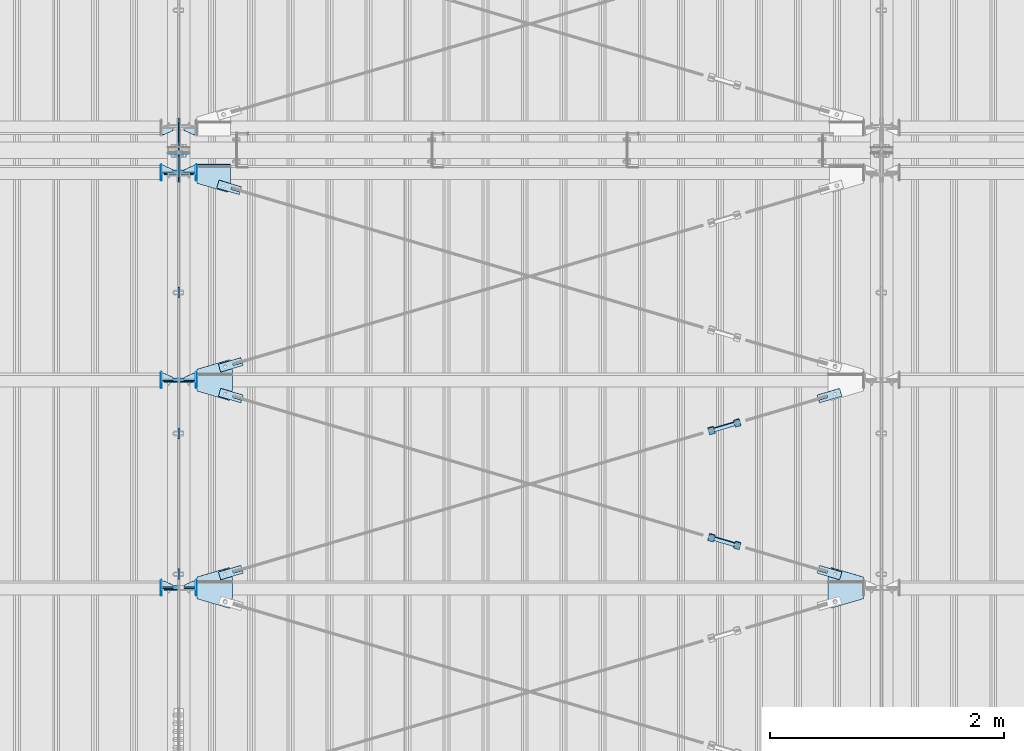
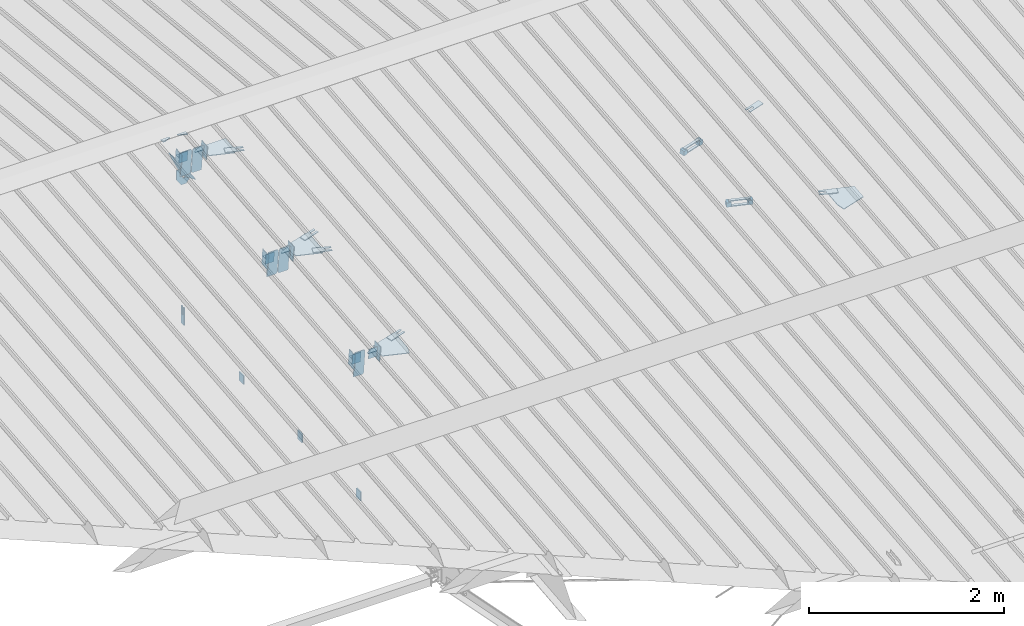
# One storey, part 151 of 709: 50 plates, 6 openings, 22 elements without a shape of their own.
"""IFC4 building model written with IfcOpenShell, lengths in millimetres."""

from ifc_helpers import new_model, si_unit, direction, frame, origin_with_axes, place, context, subcontext, project, spatial, line, indexed_curve, outline, extrude, material, element, aggregate, save


model = new_model("IFC4")

# Units and contexts
model_context = context("Model", 3, precision=0.2, world=origin_with_axes(), true_north=direction((0.0, 1.0)))
body_context = subcontext(model_context, "Body", "Model", "MODEL_VIEW")
ifc_project = project(units=[si_unit("LENGTHUNIT", "METRE", prefix="MILLI"), si_unit("AREAUNIT", "SQUARE_METRE"), si_unit("VOLUMEUNIT", "CUBIC_METRE"), si_unit("MASSUNIT", "GRAM", prefix="KILO"), si_unit("TIMEUNIT", "SECOND"), si_unit("PLANEANGLEUNIT", "RADIAN"), si_unit("SOLIDANGLEUNIT", "STERADIAN"), si_unit("THERMODYNAMICTEMPERATUREUNIT", "DEGREE_CELSIUS"), si_unit("LUMINOUSINTENSITYUNIT", "LUMEN")], contexts=[model_context])

# Site, building, storey
site_placement = place(None, origin_with_axes())
site = spatial("IfcSite", under=ifc_project, at=site_placement, CompositionType="ELEMENT")
building_placement = place(site_placement, origin_with_axes())
building = spatial("IfcBuilding", under=site, at=building_placement, Name="Undefined", CompositionType="ELEMENT")
storey_placement = place(building_placement, origin_with_axes())
storey = spatial("IfcBuildingStorey", under=building, at=storey_placement, Name="Undefined", CompositionType="ELEMENT", Elevation=0.0)

# Assembly, plates
assembly_1_placement = place(storey_placement, frame((40000.0, 346.0, 7089.70002), z_axis=(1.0, 0.0, 0.0), x_axis=(0.0, 0.9950371902, 0.099503719)))
assembly_1 = element("IfcElementAssembly", 1, at=assembly_1_placement, inside=storey)
ifc_material_1 = material(Name="C355-6", Category="STEEL")
plate_1_placement = place(assembly_1_placement, frame((10515.43997, 163.0, 127.0), z_axis=(-1.0, 0.0, 0.0), x_axis=(0.0, 0.0, -1.0)))
plate_1 = element("IfcPlate", 2, at=plate_1_placement, material=ifc_material_1, ObjectType="589", context=body_context, shape_type="SolidModel", body=[
    extrude(outline(indexed_curve([(0.0, 0.0), (108.0, 0.0), (123.0, 15.0), (123.0, 311.0), (108.0, 326.0), (0.0, 326.0)], segments=[line(1, 2, 3, 4, 5, 6, 1)])), frame((0.0, 0.0, 4.0), z_axis=(0.0, 0.0, 1.0), x_axis=(1.0, 0.0, 0.0)), (0.0, 0.0, -1.0), 8.0),
])
plate_2_placement = place(assembly_1_placement, frame((8733.29528, 163.0, 127.0), z_axis=(-1.0, 0.0, 0.0), x_axis=(0.0, 0.0, -1.0)))
plate_2 = element("IfcPlate", 3, at=plate_2_placement, material=ifc_material_1, ObjectType="585", context=body_context, shape_type="SolidModel", body=[
    extrude(outline(indexed_curve([(0.0, 0.0), (108.0, 0.0), (123.0, 15.0), (123.0, 311.0), (108.0, 326.0), (0.0, 326.0)], segments=[line(1, 2, 3, 4, 5, 6, 1)])), frame((0.0, 0.0, 4.0), z_axis=(0.0, 0.0, 1.0), x_axis=(1.0, 0.0, 0.0)), (0.0, 0.0, -1.0), 8.0),
])
plate_3_placement = place(assembly_1_placement, frame((8733.29528, 163.0, -127.0), z_axis=(1.0, 0.0, 0.0), x_axis=(0.0, 0.0, 1.0)))
plate_3 = element("IfcPlate", 4, at=plate_3_placement, material=ifc_material_1, ObjectType="585", context=body_context, shape_type="SolidModel", body=[
    extrude(outline(indexed_curve([(0.0, 0.0), (108.0, 0.0), (123.0, 15.0), (123.0, 311.0), (108.0, 326.0), (0.0, 326.0)], segments=[line(1, 2, 3, 4, 5, 6, 1)])), frame((0.0, 0.0, 4.0), z_axis=(0.0, 0.0, 1.0), x_axis=(1.0, 0.0, 0.0)), (0.0, 0.0, -1.0), 8.0),
])
plate_4_placement = place(assembly_1_placement, frame((6951.15059, 163.0, -127.0), z_axis=(1.0, 0.0, 0.0), x_axis=(0.0, 0.0, 1.0)))
plate_4 = element("IfcPlate", 5, at=plate_4_placement, material=ifc_material_1, ObjectType="585", context=body_context, shape_type="SolidModel", body=[
    extrude(outline(indexed_curve([(0.0, 0.0), (108.0, 0.0), (123.0, 15.0), (123.0, 311.0), (108.0, 326.0), (0.0, 326.0)], segments=[line(1, 2, 3, 4, 5, 6, 1)])), frame((0.0, 0.0, 4.0), z_axis=(0.0, 0.0, 1.0), x_axis=(1.0, 0.0, 0.0)), (0.0, 0.0, -1.0), 8.0),
])
plate_5_placement = place(assembly_1_placement, frame((10515.43997, 163.0, -127.0), z_axis=(1.0, 0.0, 0.0), x_axis=(0.0, 0.0, 1.0)))
plate_5 = element("IfcPlate", 6, at=plate_5_placement, material=ifc_material_1, ObjectType="589", context=body_context, shape_type="SolidModel", body=[
    extrude(outline(indexed_curve([(0.0, 0.0), (108.0, 0.0), (123.0, 15.0), (123.0, 311.0), (108.0, 326.0), (0.0, 326.0)], segments=[line(1, 2, 3, 4, 5, 6, 1)])), frame((0.0, 0.0, 4.0), z_axis=(0.0, 0.0, 1.0), x_axis=(1.0, 0.0, 0.0)), (0.0, 0.0, -1.0), 8.0),
])
plate_6_placement = place(assembly_1_placement, frame((10651.77731, -302.35483, 0.0), z_axis=(0.0, 0.0, 1.0), x_axis=(0.099503719, 0.9950371902, 0.0)))
plate_6 = element("IfcPlate", 7, at=plate_6_placement, material=ifc_material_1, ObjectType="439", context=body_context, shape_type="SolidModel", body=[
    extrude(outline(indexed_curve([(0.0, 0.0), (130.0, 0.0), (105.12407, 248.7593)], segments=[line(1, 2, 3, 1)])), frame((0.0, 0.0, 6.0), z_axis=(0.0, 0.0, 1.0), x_axis=(1.0, 0.0, 0.0)), (0.0, 0.0, -1.0), 12.0),
])
aggregate(assembly_1, [plate_1, plate_2, plate_3, plate_4, plate_5, plate_6])

# Assembly, plate
assembly_2_placement = place(storey_placement, frame((40000.0, 21654.0, 7089.70002), z_axis=(-1.0, 0.0, 0.0), x_axis=(0.0, -0.9950371902, 0.099503719)))
assembly_2 = element("IfcElementAssembly", 8, at=assembly_2_placement, inside=storey)
plate_7_placement = place(assembly_2_placement, frame((10651.77731, -302.35483, 0.0), z_axis=(0.0, 0.0, 1.0), x_axis=(0.099503719, 0.9950371902, 0.0)))
plate_7 = element("IfcPlate", 9, at=plate_7_placement, material=ifc_material_1, ObjectType="439", context=body_context, shape_type="SolidModel", body=[
    extrude(outline(indexed_curve([(0.0, 0.0), (130.0, 0.0), (105.12407, 248.7593)], segments=[line(1, 2, 3, 1)])), frame((0.0, 0.0, 6.0), z_axis=(0.0, 0.0, 1.0), x_axis=(1.0, 0.0, 0.0)), (0.0, 0.0, -1.0), 12.0),
])
aggregate(assembly_2, [plate_7])

# Assembly, plates
assembly_3_placement = place(storey_placement, frame((40000.0, 10985.0, 8155.10002), z_axis=(0.0, -1.0, 0.0), x_axis=(0.0, 0.0, -1.0)))
assembly_3 = element("IfcElementAssembly", 10, at=assembly_3_placement, inside=storey)
plate_8_placement = place(assembly_3_placement, frame((2165.1, 0.0, 30.0), z_axis=(0.0, 1.0, 0.0), x_axis=(0.0, 0.0, -1.0)))
plate_8 = element("IfcPlate", 11, at=plate_8_placement, material=ifc_material_1, ObjectType="441", context=body_context, shape_type="SolidModel", body=[
    extrude(outline(indexed_curve([(0.0, 0.0), (60.0, 0.0), (60.0, 220.0), (41.0, 220.0), (41.0, 120.0), (19.0, 120.0), (19.0, 220.0), (0.0, 220.0)], segments=[line(1, 2, 3, 4, 5, 6, 7, 8, 1)])), frame((0.0, 0.0, 6.0), z_axis=(0.0, 0.0, 1.0), x_axis=(1.0, 0.0, 0.0)), (0.0, 0.0, -1.0), 12.0),
])
plate_9_placement = place(assembly_3_placement, frame((206.36285, -87.0, 14.0), z_axis=(0.0, 0.0, -1.0), x_axis=(0.0, 1.0, 0.0)))
plate_9 = element("IfcPlate", 12, at=plate_9_placement, material=ifc_material_1, ObjectType="440", context=body_context, shape_type="SolidModel", body=[
    extrude(outline(indexed_curve([(0.0, 0.0), (71.0, 0.0), (71.0, 120.0), (103.0, 120.0), (103.0, 0.0), (174.0, 0.0), (174.0, 120.0), (117.0, 200.0), (57.0, 200.0), (0.0, 120.0)], segments=[line(1, 2, 3, 4, 5, 6, 7, 8, 9, 10, 1)])), frame((0.0, 0.0, 4.0), z_axis=(0.0, 0.0, 1.0), x_axis=(1.0, 0.0, 0.0)), (0.0, 0.0, -1.0), 8.0),
])
aggregate(assembly_3, [plate_8, plate_9])

# Assembly, plate
assembly_4_placement = place(storey_placement, frame((40000.0, 7334.75, 6100.00002), z_axis=(-1.0, 0.0, 0.0), x_axis=(0.0, 1.0, 0.0)))
assembly_4 = element("IfcElementAssembly", 13, at=assembly_4_placement, inside=storey)
plate_10_placement = place(assembly_4_placement, origin_with_axes())
plate_10 = element("IfcPlate", 14, at=plate_10_placement, material=ifc_material_1, ObjectType="491", context=body_context, shape_type="SolidModel", body=[
    extrude(outline(indexed_curve([(0.0, 0.0), (90.0, 0.0), (90.0, 110.0), (0.0, 110.0)], segments=[line(1, 2, 3, 4, 1)])), frame((0.0, 0.0, 6.0), z_axis=(0.0, 0.0, 1.0), x_axis=(1.0, 0.0, 0.0)), (0.0, 0.0, -1.0), 12.0),
])
aggregate(assembly_4, [plate_10])

assembly_5_placement = place(storey_placement, frame((40000.0, 8536.5, 6100.00002), z_axis=(-1.0, 0.0, 0.0), x_axis=(0.0, 1.0, 0.0)))
assembly_5 = element("IfcElementAssembly", 15, at=assembly_5_placement, inside=storey)
plate_11_placement = place(assembly_5_placement, origin_with_axes())
plate_11 = element("IfcPlate", 16, at=plate_11_placement, material=ifc_material_1, ObjectType="491", context=body_context, shape_type="SolidModel", body=[
    extrude(outline(indexed_curve([(0.0, 0.0), (90.0, 0.0), (90.0, 110.0), (0.0, 110.0)], segments=[line(1, 2, 3, 4, 1)])), frame((0.0, 0.0, 6.0), z_axis=(0.0, 0.0, 1.0), x_axis=(1.0, 0.0, 0.0)), (0.0, 0.0, -1.0), 12.0),
])
aggregate(assembly_5, [plate_11])

assembly_6_placement = place(storey_placement, frame((40000.0, 9738.25, 6100.00002), z_axis=(-1.0, 0.0, 0.0), x_axis=(0.0, 1.0, 0.0)))
assembly_6 = element("IfcElementAssembly", 17, at=assembly_6_placement, inside=storey)
plate_12_placement = place(assembly_6_placement, origin_with_axes())
plate_12 = element("IfcPlate", 18, at=plate_12_placement, material=ifc_material_1, ObjectType="491", context=body_context, shape_type="SolidModel", body=[
    extrude(outline(indexed_curve([(0.0, 0.0), (90.0, 0.0), (90.0, 110.0), (0.0, 110.0)], segments=[line(1, 2, 3, 4, 1)])), frame((0.0, 0.0, 6.0), z_axis=(0.0, 0.0, 1.0), x_axis=(1.0, 0.0, 0.0)), (0.0, 0.0, -1.0), 12.0),
])
aggregate(assembly_6, [plate_12])

# Assembly, plate, voiding feature
assembly_7_placement = place(storey_placement, frame((40000.0, 7262.55385, 7862.7594), z_axis=(0.2847296511, -0.9538504697, -0.095385047), x_axis=(0.9586078582, 0.2833165921, 0.028331659)))
assembly_7 = element("IfcElementAssembly", 19, at=assembly_7_placement, inside=storey)
plate_13_placement = place(assembly_7_placement, frame((363.68279, 0.0, -35.0), z_axis=(0.0, 1.0, 0.0), x_axis=(0.0, 0.0, 1.0)))
plate_13 = element("IfcPlate", 20, at=plate_13_placement, material=ifc_material_1, ObjectType="574", context=body_context, shape_type="SolidModel", body=[
    extrude(outline(indexed_curve([(0.0, 0.0), (70.0, 0.0), (70.0, 200.0), (0.0, 200.0)], segments=[line(1, 2, 3, 4, 1)])), frame((0.0, 0.0, 4.0), z_axis=(0.0, 0.0, 1.0), x_axis=(1.0, 0.0, 0.0)), (0.0, 0.0, -1.0), 8.0),
])
voiding_feature_1_placement = place(plate_13_placement, frame((24.0, 120.0, 0.0), z_axis=(0.0, 0.0, 1.0), x_axis=(1.0, 0.0, 0.0)))
element("IfcVoidingFeature", 21, at=voiding_feature_1_placement, cuts=plate_13, Name="PLATE", PredefinedType="HOLE", context=body_context, shape_type="SolidModel", body=[
    extrude(outline(indexed_curve([(0.0, 0.0), (22.0, 0.0), (22.0, 85.0), (0.0, 85.0)], segments=[line(1, 2, 3, 4, 1)])), frame((0.0, 0.0, 6.5), z_axis=(0.0, 0.0, 1.0), x_axis=(1.0, 0.0, 0.0)), (0.0, 0.0, -1.0), 13.0),
])
aggregate(assembly_7, [plate_13])

assembly_8_placement = place(storey_placement, frame((44657.949, 8639.21087, 8000.4251), z_axis=(0.2847296511, -0.9538504697, -0.095385047), x_axis=(0.9586078582, 0.2833165921, 0.028331659)))
assembly_8 = element("IfcElementAssembly", 22, at=assembly_8_placement, inside=storey)
plate_14_placement = place(assembly_8_placement, frame((1036.31721, 0.0, 35.0), z_axis=(0.0, 1.0, 0.0), x_axis=(0.0, 0.0, -1.0)))
plate_14 = element("IfcPlate", 23, at=plate_14_placement, material=ifc_material_1, ObjectType="574", context=body_context, shape_type="SolidModel", body=[
    extrude(outline(indexed_curve([(0.0, 0.0), (70.0, 0.0), (70.0, 200.0), (0.0, 200.0)], segments=[line(1, 2, 3, 4, 1)])), frame((0.0, 0.0, 4.0), z_axis=(0.0, 0.0, 1.0), x_axis=(1.0, 0.0, 0.0)), (0.0, 0.0, -1.0), 8.0),
])
voiding_feature_2_placement = place(plate_14_placement, frame((24.0, 120.0, 0.0), z_axis=(0.0, 0.0, 1.0), x_axis=(1.0, 0.0, 0.0)))
element("IfcVoidingFeature", 24, at=voiding_feature_2_placement, cuts=plate_14, Name="PLATE", PredefinedType="HOLE", context=body_context, shape_type="SolidModel", body=[
    extrude(outline(indexed_curve([(0.0, 0.0), (22.0, 0.0), (22.0, 85.0), (0.0, 85.0)], segments=[line(1, 2, 3, 4, 1)])), frame((0.0, 0.0, 6.5), z_axis=(0.0, 0.0, 1.0), x_axis=(1.0, 0.0, 0.0)), (0.0, 0.0, -1.0), 13.0),
])
aggregate(assembly_8, [plate_14])

# Assembly, plates
assembly_9_placement = place(storey_placement, frame((44776.73079, 8640.19165, 8030.67281), z_axis=(-0.9586078582, -0.2833165918, -0.0283316592), x_axis=(-0.2847296509, 0.9538504698, 0.095385047)))
assembly_9 = element("IfcElementAssembly", 25, at=assembly_9_placement, inside=storey)
ifc_material_2 = material(Name="Steel_Undefined", Category="STEEL")
plate_15_placement = place(assembly_9_placement, frame((0.0, 0.0, 230.0), z_axis=(0.0, 0.0, 1.0), x_axis=(1.0, 0.0, 0.0)))
plate_15 = element("IfcPlate", 26, at=plate_15_placement, material=ifc_material_2, ObjectType="483", context=body_context, shape_type="SolidModel", body=[
    extrude(outline(indexed_curve([(0.0, 0.0), (60.0, 0.0), (60.0, 60.0), (0.0, 60.0)], segments=[line(1, 2, 3, 4, 1)])), frame((0.0, 0.0, 25.0), z_axis=(0.0, 0.0, 1.0), x_axis=(1.0, 0.0, 0.0)), (0.0, 0.0, -1.0), 50.0),
])
plate_16_placement = place(assembly_9_placement, frame((15.0, 66.0, 230.0), z_axis=(0.0, 1.0, 0.0), x_axis=(1.0, 0.0, 0.0)))
plate_16 = element("IfcPlate", 27, at=plate_16_placement, material=ifc_material_2, ObjectType="484", context=body_context, shape_type="SolidModel", body=[
    extrude(outline(indexed_curve([(0.0, 0.0), (30.0, 0.0), (30.0, 230.0), (0.0, 230.0)], segments=[line(1, 2, 3, 4, 1)])), frame((0.0, 0.0, 6.0), z_axis=(0.0, 0.0, 1.0), x_axis=(1.0, 0.0, 0.0)), (0.0, 0.0, -1.0), 12.0),
])
plate_17_placement = place(assembly_9_placement, frame((15.0, -6.0, 230.0), z_axis=(0.0, 1.0, 0.0), x_axis=(1.0, 0.0, 0.0)))
plate_17 = element("IfcPlate", 28, at=plate_17_placement, material=ifc_material_2, ObjectType="484", context=body_context, shape_type="SolidModel", body=[
    extrude(outline(indexed_curve([(0.0, 0.0), (30.0, 0.0), (30.0, 230.0), (0.0, 230.0)], segments=[line(1, 2, 3, 4, 1)])), frame((0.0, 0.0, 6.0), z_axis=(0.0, 0.0, 1.0), x_axis=(1.0, 0.0, 0.0)), (0.0, 0.0, -1.0), 12.0),
])
plate_18_placement = place(assembly_9_placement, origin_with_axes())
plate_18 = element("IfcPlate", 29, at=plate_18_placement, material=ifc_material_2, ObjectType="482", context=body_context, shape_type="SolidModel", body=[
    extrude(outline(indexed_curve([(0.0, 0.0), (60.0, 0.0), (60.0, 60.0), (0.0, 60.0)], segments=[line(1, 2, 3, 4, 1)])), frame((0.0, 0.0, 25.0), z_axis=(0.0, 0.0, 1.0), x_axis=(1.0, 0.0, 0.0)), (0.0, 0.0, -1.0), 50.0),
])
aggregate(assembly_9, [plate_15, plate_16, plate_17, plate_18])

# Assembly, plate, voiding feature
assembly_10_placement = place(storey_placement, frame((40000.0, 9035.85409, 8040.08943), z_axis=(-0.2847296511, -0.9538504697, -0.095385047), x_axis=(0.9586078582, -0.2833165921, -0.028331659)))
assembly_10 = element("IfcElementAssembly", 30, at=assembly_10_placement, inside=storey)
plate_19_placement = place(assembly_10_placement, frame((363.68279, 0.0, -35.0), z_axis=(0.0, 1.0, 0.0), x_axis=(0.0, 0.0, 1.0)))
plate_19 = element("IfcPlate", 31, at=plate_19_placement, material=ifc_material_1, ObjectType="574", context=body_context, shape_type="SolidModel", body=[
    extrude(outline(indexed_curve([(0.0, 0.0), (70.0, 0.0), (70.0, 200.0), (0.0, 200.0)], segments=[line(1, 2, 3, 4, 1)])), frame((0.0, 0.0, 4.0), z_axis=(0.0, 0.0, 1.0), x_axis=(1.0, 0.0, 0.0)), (0.0, 0.0, -1.0), 8.0),
])
voiding_feature_3_placement = place(plate_19_placement, frame((24.0, 120.0, 0.0), z_axis=(0.0, 0.0, 1.0), x_axis=(1.0, 0.0, 0.0)))
element("IfcVoidingFeature", 32, at=voiding_feature_3_placement, cuts=plate_19, Name="PLATE", PredefinedType="HOLE", context=body_context, shape_type="SolidModel", body=[
    extrude(outline(indexed_curve([(0.0, 0.0), (22.0, 0.0), (22.0, 85.0), (0.0, 85.0)], segments=[line(1, 2, 3, 4, 1)])), frame((0.0, 0.0, 6.5), z_axis=(0.0, 0.0, 1.0), x_axis=(1.0, 0.0, 0.0)), (0.0, 0.0, -1.0), 13.0),
])
aggregate(assembly_10, [plate_19])

assembly_11_placement = place(storey_placement, frame((44657.949, 7659.19708, 7902.42372), z_axis=(-0.2847296511, -0.9538504697, -0.095385047), x_axis=(0.9586078582, -0.2833165921, -0.028331659)))
assembly_11 = element("IfcElementAssembly", 33, at=assembly_11_placement, inside=storey)
plate_20_placement = place(assembly_11_placement, frame((1036.31721, 0.0, 35.0), z_axis=(0.0, 1.0, 0.0), x_axis=(0.0, 0.0, -1.0)))
plate_20 = element("IfcPlate", 34, at=plate_20_placement, material=ifc_material_1, ObjectType="574", context=body_context, shape_type="SolidModel", body=[
    extrude(outline(indexed_curve([(0.0, 0.0), (70.0, 0.0), (70.0, 200.0), (0.0, 200.0)], segments=[line(1, 2, 3, 4, 1)])), frame((0.0, 0.0, 4.0), z_axis=(0.0, 0.0, 1.0), x_axis=(1.0, 0.0, 0.0)), (0.0, 0.0, -1.0), 8.0),
])
voiding_feature_4_placement = place(plate_20_placement, frame((24.0, 120.0, 0.0), z_axis=(0.0, 0.0, 1.0), x_axis=(1.0, 0.0, 0.0)))
element("IfcVoidingFeature", 35, at=voiding_feature_4_placement, cuts=plate_20, Name="PLATE", PredefinedType="HOLE", context=body_context, shape_type="SolidModel", body=[
    extrude(outline(indexed_curve([(0.0, 0.0), (22.0, 0.0), (22.0, 85.0), (0.0, 85.0)], segments=[line(1, 2, 3, 4, 1)])), frame((0.0, 0.0, 6.5), z_axis=(0.0, 0.0, 1.0), x_axis=(1.0, 0.0, 0.0)), (0.0, 0.0, -1.0), 13.0),
])
aggregate(assembly_11, [plate_20])

# Assembly, plates
assembly_12_placement = place(storey_placement, frame((44759.64701, 7595.01504, 7926.15515), z_axis=(-0.9586078582, 0.2833165918, 0.0283316592), x_axis=(0.2847296509, 0.9538504698, 0.095385047)))
assembly_12 = element("IfcElementAssembly", 36, at=assembly_12_placement, inside=storey)
plate_21_placement = place(assembly_12_placement, origin_with_axes())
plate_21 = element("IfcPlate", 37, at=plate_21_placement, material=ifc_material_2, ObjectType="482", context=body_context, shape_type="SolidModel", body=[
    extrude(outline(indexed_curve([(0.0, 0.0), (60.0, 0.0), (60.0, 60.0), (0.0, 60.0)], segments=[line(1, 2, 3, 4, 1)])), frame((0.0, 0.0, 25.0), z_axis=(0.0, 0.0, 1.0), x_axis=(1.0, 0.0, 0.0)), (0.0, 0.0, -1.0), 50.0),
])
plate_22_placement = place(assembly_12_placement, frame((0.0, 0.0, 230.0), z_axis=(0.0, 0.0, 1.0), x_axis=(1.0, 0.0, 0.0)))
plate_22 = element("IfcPlate", 38, at=plate_22_placement, material=ifc_material_2, ObjectType="483", context=body_context, shape_type="SolidModel", body=[
    extrude(outline(indexed_curve([(0.0, 0.0), (60.0, 0.0), (60.0, 60.0), (0.0, 60.0)], segments=[line(1, 2, 3, 4, 1)])), frame((0.0, 0.0, 25.0), z_axis=(0.0, 0.0, 1.0), x_axis=(1.0, 0.0, 0.0)), (0.0, 0.0, -1.0), 50.0),
])
plate_23_placement = place(assembly_12_placement, frame((15.0, -6.0, 230.0), z_axis=(0.0, 1.0, 0.0), x_axis=(1.0, 0.0, 0.0)))
plate_23 = element("IfcPlate", 39, at=plate_23_placement, material=ifc_material_2, ObjectType="484", context=body_context, shape_type="SolidModel", body=[
    extrude(outline(indexed_curve([(0.0, 0.0), (30.0, 0.0), (30.0, 230.0), (0.0, 230.0)], segments=[line(1, 2, 3, 4, 1)])), frame((0.0, 0.0, 6.0), z_axis=(0.0, 0.0, 1.0), x_axis=(1.0, 0.0, 0.0)), (0.0, 0.0, -1.0), 12.0),
])
plate_24_placement = place(assembly_12_placement, frame((15.0, 66.0, 230.0), z_axis=(0.0, 1.0, 0.0), x_axis=(1.0, 0.0, 0.0)))
plate_24 = element("IfcPlate", 40, at=plate_24_placement, material=ifc_material_2, ObjectType="484", context=body_context, shape_type="SolidModel", body=[
    extrude(outline(indexed_curve([(0.0, 0.0), (30.0, 0.0), (30.0, 230.0), (0.0, 230.0)], segments=[line(1, 2, 3, 4, 1)])), frame((0.0, 0.0, 6.0), z_axis=(0.0, 0.0, 1.0), x_axis=(1.0, 0.0, 0.0)), (0.0, 0.0, -1.0), 12.0),
])
aggregate(assembly_12, [plate_21, plate_22, plate_23, plate_24])

# Assembly, plate, voiding feature
assembly_13_placement = place(storey_placement, frame((40000.0, 9035.85409, 8040.08943), z_axis=(0.2847296511, -0.9538504697, -0.095385047), x_axis=(0.9586078582, 0.2833165921, 0.028331659)))
assembly_13 = element("IfcElementAssembly", 41, at=assembly_13_placement, inside=storey)
plate_25_placement = place(assembly_13_placement, frame((363.68279, 0.0, -35.0), z_axis=(0.0, 1.0, 0.0), x_axis=(0.0, 0.0, 1.0)))
plate_25 = element("IfcPlate", 42, at=plate_25_placement, material=ifc_material_1, ObjectType="574", context=body_context, shape_type="SolidModel", body=[
    extrude(outline(indexed_curve([(0.0, 0.0), (70.0, 0.0), (70.0, 200.0), (0.0, 200.0)], segments=[line(1, 2, 3, 4, 1)])), frame((0.0, 0.0, 4.0), z_axis=(0.0, 0.0, 1.0), x_axis=(1.0, 0.0, 0.0)), (0.0, 0.0, -1.0), 8.0),
])
voiding_feature_5_placement = place(plate_25_placement, frame((24.0, 120.0, 0.0), z_axis=(0.0, 0.0, 1.0), x_axis=(1.0, 0.0, 0.0)))
element("IfcVoidingFeature", 43, at=voiding_feature_5_placement, cuts=plate_25, Name="PLATE", PredefinedType="HOLE", context=body_context, shape_type="SolidModel", body=[
    extrude(outline(indexed_curve([(0.0, 0.0), (22.0, 0.0), (22.0, 85.0), (0.0, 85.0)], segments=[line(1, 2, 3, 4, 1)])), frame((0.0, 0.0, 6.5), z_axis=(0.0, 0.0, 1.0), x_axis=(1.0, 0.0, 0.0)), (0.0, 0.0, -1.0), 13.0),
])
aggregate(assembly_13, [plate_25])

assembly_14_placement = place(storey_placement, frame((40000.0, 10809.15434, 8217.41945), z_axis=(-0.2847296511, -0.9538504697, -0.095385047), x_axis=(0.9586078582, -0.2833165921, -0.028331659)))
assembly_14 = element("IfcElementAssembly", 44, at=assembly_14_placement, inside=storey)
plate_26_placement = place(assembly_14_placement, frame((348.68279, 0.0, -35.0), z_axis=(0.0, 1.0, 0.0), x_axis=(0.0, 0.0, 1.0)))
plate_26 = element("IfcPlate", 45, at=plate_26_placement, material=ifc_material_1, ObjectType="574", context=body_context, shape_type="SolidModel", body=[
    extrude(outline(indexed_curve([(0.0, 0.0), (70.0, 0.0), (70.0, 200.0), (0.0, 200.0)], segments=[line(1, 2, 3, 4, 1)])), frame((0.0, 0.0, 4.0), z_axis=(0.0, 0.0, 1.0), x_axis=(1.0, 0.0, 0.0)), (0.0, 0.0, -1.0), 8.0),
])
voiding_feature_6_placement = place(plate_26_placement, frame((24.0, 120.0, 0.0), z_axis=(0.0, 0.0, 1.0), x_axis=(1.0, 0.0, 0.0)))
element("IfcVoidingFeature", 46, at=voiding_feature_6_placement, cuts=plate_26, Name="PLATE", PredefinedType="HOLE", context=body_context, shape_type="SolidModel", body=[
    extrude(outline(indexed_curve([(0.0, 0.0), (22.0, 0.0), (22.0, 85.0), (0.0, 85.0)], segments=[line(1, 2, 3, 4, 1)])), frame((0.0, 0.0, 6.5), z_axis=(0.0, 0.0, 1.0), x_axis=(1.0, 0.0, 0.0)), (0.0, 0.0, -1.0), 13.0),
])
aggregate(assembly_14, [plate_26])

# Assembly, plates
assembly_15_placement = place(storey_placement, frame((34000.0, 7263.34988, 7854.7991), z_axis=(0.0, 0.9950371902, 0.099503719), x_axis=(1.0, 0.0, 0.0)))
assembly_15 = element("IfcElementAssembly", 47, at=assembly_15_placement, inside=storey)
plate_27_placement = place(assembly_15_placement, frame((5953.0, 65.0, 0.0), z_axis=(0.0, 0.0, 1.0), x_axis=(-1.0, 0.0, 0.0)))
plate_27 = element("IfcPlate", 48, at=plate_27_placement, material=ifc_material_1, ObjectType="587", context=body_context, shape_type="SolidModel", body=[
    extrude(outline(indexed_curve([(0.0, 0.0), (100.0, 0.0), (100.0, 130.0), (0.0, 130.0)], segments=[line(1, 2, 3, 4, 1)])), frame((0.0, 0.0, 4.0), z_axis=(0.0, 0.0, 1.0), x_axis=(1.0, 0.0, 0.0)), (0.0, 0.0, -1.0), 8.0),
])
plate_28_placement = place(assembly_15_placement, frame((5849.0, -98.0, 60.0), z_axis=(1.0, 0.0, 0.0), x_axis=(0.0, 0.0, -1.0)))
plate_28 = element("IfcPlate", 49, at=plate_28_placement, material=ifc_material_1, ObjectType="586", context=body_context, shape_type="SolidModel", body=[
    extrude(outline(indexed_curve([(0.0, 0.0), (120.0, 0.0), (120.0, 196.0), (0.0, 196.0)], segments=[line(1, 2, 3, 4, 1)])), frame((0.0, 0.0, 4.0), z_axis=(0.0, 0.0, 1.0), x_axis=(1.0, 0.0, 0.0)), (0.0, 0.0, -1.0), 8.0),
])
plate_29_placement = place(assembly_15_placement, frame((5953.0, 0.0, 60.0), z_axis=(0.0, -1.0, 0.0), x_axis=(-1.0, 0.0, 0.0)))
plate_29 = element("IfcPlate", 50, at=plate_29_placement, material=ifc_material_1, ObjectType="588", context=body_context, shape_type="SolidModel", body=[
    extrude(outline(indexed_curve([(0.0, 36.0), (80.0, 0.0), (100.0, 0.0), (100.0, 56.0), (0.0, 56.0)], segments=[line(1, 2, 3, 4, 5, 1)])), frame((0.0, 0.0, 4.0), z_axis=(0.0, 0.0, 1.0), x_axis=(1.0, 0.0, 0.0)), (0.0, 0.0, -1.0), 8.0),
])
aggregate(assembly_15, [plate_27, plate_28, plate_29])

assembly_16_placement = place(storey_placement, frame((34000.0, 9036.65012, 8032.12913), z_axis=(0.0, 0.9950371902, 0.099503719), x_axis=(1.0, 0.0, 0.0)))
assembly_16 = element("IfcElementAssembly", 51, at=assembly_16_placement, inside=storey)
plate_30_placement = place(assembly_16_placement, frame((5953.0, 0.0, 60.0), z_axis=(0.0, -1.0, 0.0), x_axis=(-1.0, 0.0, 0.0)))
plate_30 = element("IfcPlate", 52, at=plate_30_placement, material=ifc_material_1, ObjectType="588", context=body_context, shape_type="SolidModel", body=[
    extrude(outline(indexed_curve([(0.0, 36.0), (80.0, 0.0), (100.0, 0.0), (100.0, 56.0), (0.0, 56.0)], segments=[line(1, 2, 3, 4, 5, 1)])), frame((0.0, 0.0, 4.0), z_axis=(0.0, 0.0, 1.0), x_axis=(1.0, 0.0, 0.0)), (0.0, 0.0, -1.0), 8.0),
])
plate_31_placement = place(assembly_16_placement, frame((5849.0, -98.0, 60.0), z_axis=(1.0, 0.0, 0.0), x_axis=(0.0, 0.0, -1.0)))
plate_31 = element("IfcPlate", 53, at=plate_31_placement, material=ifc_material_1, ObjectType="586", context=body_context, shape_type="SolidModel", body=[
    extrude(outline(indexed_curve([(0.0, 0.0), (120.0, 0.0), (120.0, 196.0), (0.0, 196.0)], segments=[line(1, 2, 3, 4, 1)])), frame((0.0, 0.0, 4.0), z_axis=(0.0, 0.0, 1.0), x_axis=(1.0, 0.0, 0.0)), (0.0, 0.0, -1.0), 8.0),
])
plate_32_placement = place(assembly_16_placement, frame((5953.0, 65.0, 0.0), z_axis=(0.0, 0.0, 1.0), x_axis=(-1.0, 0.0, 0.0)))
plate_32 = element("IfcPlate", 54, at=plate_32_placement, material=ifc_material_1, ObjectType="587", context=body_context, shape_type="SolidModel", body=[
    extrude(outline(indexed_curve([(0.0, 0.0), (100.0, 0.0), (100.0, 130.0), (0.0, 130.0)], segments=[line(1, 2, 3, 4, 1)])), frame((0.0, 0.0, 4.0), z_axis=(0.0, 0.0, 1.0), x_axis=(1.0, 0.0, 0.0)), (0.0, 0.0, -1.0), 8.0),
])
aggregate(assembly_16, [plate_30, plate_31, plate_32])

assembly_17_placement = place(storey_placement, frame((34000.0, 10808.95533, 8219.40952), z_axis=(0.0, 0.9950371902, 0.099503719), x_axis=(1.0, 0.0, 0.0)))
assembly_17 = element("IfcElementAssembly", 55, at=assembly_17_placement, inside=storey)
plate_33_placement = place(assembly_17_placement, frame((5953.0, 65.0, 0.0), z_axis=(0.0, 0.0, 1.0), x_axis=(-1.0, 0.0, 0.0)))
plate_33 = element("IfcPlate", 56, at=plate_33_placement, material=ifc_material_1, ObjectType="587", context=body_context, shape_type="SolidModel", body=[
    extrude(outline(indexed_curve([(0.0, 0.0), (100.0, 0.0), (100.0, 130.0), (0.0, 130.0)], segments=[line(1, 2, 3, 4, 1)])), frame((0.0, 0.0, 4.0), z_axis=(0.0, 0.0, 1.0), x_axis=(1.0, 0.0, 0.0)), (0.0, 0.0, -1.0), 8.0),
])
plate_34_placement = place(assembly_17_placement, frame((5849.0, -88.0, 60.0), z_axis=(1.0, 0.0, 0.0), x_axis=(0.0, 0.0, -1.0)))
plate_34 = element("IfcPlate", 57, at=plate_34_placement, material=ifc_material_1, ObjectType="590", context=body_context, shape_type="SolidModel", body=[
    extrude(outline(indexed_curve([(0.0, 0.0), (120.0, 0.0), (120.0, 176.0), (0.0, 176.0)], segments=[line(1, 2, 3, 4, 1)])), frame((0.0, 0.0, 4.0), z_axis=(0.0, 0.0, 1.0), x_axis=(1.0, 0.0, 0.0)), (0.0, 0.0, -1.0), 8.0),
])
plate_35_placement = place(assembly_17_placement, frame((5953.0, 0.0, 60.0), z_axis=(0.0, -1.0, 0.0), x_axis=(-1.0, 0.0, 0.0)))
plate_35 = element("IfcPlate", 58, at=plate_35_placement, material=ifc_material_1, ObjectType="588", context=body_context, shape_type="SolidModel", body=[
    extrude(outline(indexed_curve([(0.0, 36.0), (80.0, 0.0), (100.0, 0.0), (100.0, 56.0), (0.0, 56.0)], segments=[line(1, 2, 3, 4, 5, 1)])), frame((0.0, 0.0, 4.0), z_axis=(0.0, 0.0, 1.0), x_axis=(1.0, 0.0, 0.0)), (0.0, 0.0, -1.0), 8.0),
])
aggregate(assembly_17, [plate_33, plate_34, plate_35])

# Assembly, plate
assembly_18_placement = place(storey_placement, frame((40000.0, 11191.04467, 8219.40952), z_axis=(0.0, -0.9950371902, 0.099503719), x_axis=(-1.0, 0.0, 0.0)))
assembly_18 = element("IfcElementAssembly", 59, at=assembly_18_placement, inside=storey)
plate_36_placement = place(assembly_18_placement, frame((47.0, 0.0, 60.0), z_axis=(0.0, 1.0, 0.0), x_axis=(1.0, 0.0, 0.0)))
plate_36 = element("IfcPlate", 60, at=plate_36_placement, material=ifc_material_1, ObjectType="588", context=body_context, shape_type="SolidModel", body=[
    extrude(outline(indexed_curve([(0.0, 36.0), (80.0, 0.0), (100.0, 0.0), (100.0, 56.0), (0.0, 56.0)], segments=[line(1, 2, 3, 4, 5, 1)])), frame((0.0, 0.0, 4.0), z_axis=(0.0, 0.0, 1.0), x_axis=(1.0, 0.0, 0.0)), (0.0, 0.0, -1.0), 8.0),
])
aggregate(assembly_18, [plate_36])

# Assembly, plates
assembly_19_placement = place(storey_placement, frame((40000.0, 7263.34988, 7854.7991), z_axis=(0.0, 0.9950371902, 0.099503719), x_axis=(1.0, 0.0, 0.0)))
assembly_19 = element("IfcElementAssembly", 61, at=assembly_19_placement, inside=storey)
plate_37_placement = place(assembly_19_placement, frame((47.0, 0.0, 60.0), z_axis=(0.0, 1.0, 0.0), x_axis=(1.0, 0.0, 0.0)))
plate_37 = element("IfcPlate", 62, at=plate_37_placement, material=ifc_material_1, ObjectType="588", context=body_context, shape_type="SolidModel", body=[
    extrude(outline(indexed_curve([(0.0, 36.0), (80.0, 0.0), (100.0, 0.0), (100.0, 56.0), (0.0, 56.0)], segments=[line(1, 2, 3, 4, 5, 1)])), frame((0.0, 0.0, 4.0), z_axis=(0.0, 0.0, 1.0), x_axis=(1.0, 0.0, 0.0)), (0.0, 0.0, -1.0), 8.0),
])
plate_38_placement = place(assembly_19_placement, frame((47.0, -65.0, 0.0), z_axis=(0.0, 0.0, 1.0), x_axis=(1.0, 0.0, 0.0)))
plate_38 = element("IfcPlate", 63, at=plate_38_placement, material=ifc_material_1, ObjectType="587", context=body_context, shape_type="SolidModel", body=[
    extrude(outline(indexed_curve([(0.0, 0.0), (100.0, 0.0), (100.0, 130.0), (0.0, 130.0)], segments=[line(1, 2, 3, 4, 1)])), frame((0.0, 0.0, 4.0), z_axis=(0.0, 0.0, 1.0), x_axis=(1.0, 0.0, 0.0)), (0.0, 0.0, -1.0), 8.0),
])
plate_39_placement = place(assembly_19_placement, frame((151.0, -98.0, -60.0), z_axis=(-1.0, 0.0, 0.0), x_axis=(0.0, 0.0, 1.0)))
plate_39 = element("IfcPlate", 64, at=plate_39_placement, material=ifc_material_1, ObjectType="586", context=body_context, shape_type="SolidModel", body=[
    extrude(outline(indexed_curve([(0.0, 0.0), (120.0, 0.0), (120.0, 196.0), (0.0, 196.0)], segments=[line(1, 2, 3, 4, 1)])), frame((0.0, 0.0, 4.0), z_axis=(0.0, 0.0, 1.0), x_axis=(1.0, 0.0, 0.0)), (0.0, 0.0, -1.0), 8.0),
])
plate_40_placement = place(assembly_19_placement, frame((154.99945, 0.0, 92.98165), z_axis=(0.0, -1.0, 0.0), x_axis=(0.0, 0.0, -1.0)))
plate_40 = element("IfcPlate", 65, at=plate_40_placement, material=ifc_material_1, ObjectType="576", context=body_context, shape_type="SolidModel", body=[
    extrude(outline(indexed_curve([(0.0, 0.0), (185.9633, 0.0), (268.14324, 276.67769), (181.86854, 302.30336), (4.09476, 302.30336), (-82.17995, 276.67769)], segments=[line(1, 2, 3, 4, 5, 6, 1)])), frame((0.0, 0.0, 4.0), z_axis=(0.0, 0.0, 1.0), x_axis=(1.0, 0.0, 0.0)), (0.0, 0.0, -1.0), 8.0),
])
plate_41_placement = place(assembly_19_placement, frame((5845.00055, 0.0, -92.98165), z_axis=(0.0, -1.0, 0.0), x_axis=(0.0, 0.0, 1.0)))
plate_41 = element("IfcPlate", 66, at=plate_41_placement, material=ifc_material_1, ObjectType="576", context=body_context, shape_type="SolidModel", body=[
    extrude(outline(indexed_curve([(0.0, 0.0), (185.9633, 0.0), (268.14324, 276.67769), (181.86854, 302.30336), (4.09476, 302.30336), (-82.17995, 276.67769)], segments=[line(1, 2, 3, 4, 5, 6, 1)])), frame((0.0, 0.0, 4.0), z_axis=(0.0, 0.0, 1.0), x_axis=(1.0, 0.0, 0.0)), (0.0, 0.0, -1.0), 8.0),
])
aggregate(assembly_19, [plate_37, plate_38, plate_39, plate_40, plate_41])

assembly_20_placement = place(storey_placement, frame((40000.0, 9036.65012, 8032.12913), z_axis=(0.0, 0.9950371902, 0.099503719), x_axis=(1.0, 0.0, 0.0)))
assembly_20 = element("IfcElementAssembly", 67, at=assembly_20_placement, inside=storey)
plate_42_placement = place(assembly_20_placement, frame((151.0, -98.0, -60.0), z_axis=(-1.0, 0.0, 0.0), x_axis=(0.0, 0.0, 1.0)))
plate_42 = element("IfcPlate", 68, at=plate_42_placement, material=ifc_material_1, ObjectType="586", context=body_context, shape_type="SolidModel", body=[
    extrude(outline(indexed_curve([(0.0, 0.0), (120.0, 0.0), (120.0, 196.0), (0.0, 196.0)], segments=[line(1, 2, 3, 4, 1)])), frame((0.0, 0.0, 4.0), z_axis=(0.0, 0.0, 1.0), x_axis=(1.0, 0.0, 0.0)), (0.0, 0.0, -1.0), 8.0),
])
plate_43_placement = place(assembly_20_placement, frame((47.0, -65.0, 0.0), z_axis=(0.0, 0.0, 1.0), x_axis=(1.0, 0.0, 0.0)))
plate_43 = element("IfcPlate", 69, at=plate_43_placement, material=ifc_material_1, ObjectType="587", context=body_context, shape_type="SolidModel", body=[
    extrude(outline(indexed_curve([(0.0, 0.0), (100.0, 0.0), (100.0, 130.0), (0.0, 130.0)], segments=[line(1, 2, 3, 4, 1)])), frame((0.0, 0.0, 4.0), z_axis=(0.0, 0.0, 1.0), x_axis=(1.0, 0.0, 0.0)), (0.0, 0.0, -1.0), 8.0),
])
plate_44_placement = place(assembly_20_placement, frame((154.99945, 0.0, 92.98165), z_axis=(0.0, -1.0, 0.0), x_axis=(0.0, 0.0, -1.0)))
plate_44 = element("IfcPlate", 70, at=plate_44_placement, material=ifc_material_1, ObjectType="576", context=body_context, shape_type="SolidModel", body=[
    extrude(outline(indexed_curve([(0.0, 0.0), (185.9633, 0.0), (268.14324, 276.67769), (181.86854, 302.30336), (4.09476, 302.30336), (-82.17995, 276.67769)], segments=[line(1, 2, 3, 4, 5, 6, 1)])), frame((0.0, 0.0, 4.0), z_axis=(0.0, 0.0, 1.0), x_axis=(1.0, 0.0, 0.0)), (0.0, 0.0, -1.0), 8.0),
])
plate_45_placement = place(assembly_20_placement, frame((47.0, 0.0, 60.0), z_axis=(0.0, 1.0, 0.0), x_axis=(1.0, 0.0, 0.0)))
plate_45 = element("IfcPlate", 71, at=plate_45_placement, material=ifc_material_1, ObjectType="588", context=body_context, shape_type="SolidModel", body=[
    extrude(outline(indexed_curve([(0.0, 36.0), (80.0, 0.0), (100.0, 0.0), (100.0, 56.0), (0.0, 56.0)], segments=[line(1, 2, 3, 4, 5, 1)])), frame((0.0, 0.0, 4.0), z_axis=(0.0, 0.0, 1.0), x_axis=(1.0, 0.0, 0.0)), (0.0, 0.0, -1.0), 8.0),
])
aggregate(assembly_20, [plate_42, plate_43, plate_44, plate_45])

assembly_21_placement = place(storey_placement, frame((40000.0, 10808.95533, 8219.40952), z_axis=(0.0, 0.9950371902, 0.099503719), x_axis=(1.0, 0.0, 0.0)))
assembly_21 = element("IfcElementAssembly", 72, at=assembly_21_placement, inside=storey)
plate_46_placement = place(assembly_21_placement, frame((47.0, 0.0, 60.0), z_axis=(0.0, 1.0, 0.0), x_axis=(1.0, 0.0, 0.0)))
plate_46 = element("IfcPlate", 73, at=plate_46_placement, material=ifc_material_1, ObjectType="588", context=body_context, shape_type="SolidModel", body=[
    extrude(outline(indexed_curve([(0.0, 36.0), (80.0, 0.0), (100.0, 0.0), (100.0, 56.0), (0.0, 56.0)], segments=[line(1, 2, 3, 4, 5, 1)])), frame((0.0, 0.0, 4.0), z_axis=(0.0, 0.0, 1.0), x_axis=(1.0, 0.0, 0.0)), (0.0, 0.0, -1.0), 8.0),
])
plate_47_placement = place(assembly_21_placement, frame((47.0, -65.0, 0.0), z_axis=(0.0, 0.0, 1.0), x_axis=(1.0, 0.0, 0.0)))
plate_47 = element("IfcPlate", 74, at=plate_47_placement, material=ifc_material_1, ObjectType="587", context=body_context, shape_type="SolidModel", body=[
    extrude(outline(indexed_curve([(0.0, 0.0), (100.0, 0.0), (100.0, 130.0), (0.0, 130.0)], segments=[line(1, 2, 3, 4, 1)])), frame((0.0, 0.0, 4.0), z_axis=(0.0, 0.0, 1.0), x_axis=(1.0, 0.0, 0.0)), (0.0, 0.0, -1.0), 8.0),
])
plate_48_placement = place(assembly_21_placement, frame((151.0, -88.0, -60.0), z_axis=(-1.0, 0.0, 0.0), x_axis=(0.0, 0.0, 1.0)))
plate_48 = element("IfcPlate", 75, at=plate_48_placement, material=ifc_material_1, ObjectType="590", context=body_context, shape_type="SolidModel", body=[
    extrude(outline(indexed_curve([(0.0, 0.0), (120.0, 0.0), (120.0, 176.0), (0.0, 176.0)], segments=[line(1, 2, 3, 4, 1)])), frame((0.0, 0.0, 4.0), z_axis=(0.0, 0.0, 1.0), x_axis=(1.0, 0.0, 0.0)), (0.0, 0.0, -1.0), 8.0),
])
plate_49_placement = place(assembly_21_placement, frame((442.92369, 10.0, 70.0), z_axis=(0.0, -1.0, 0.0), x_axis=(-1.0, 0.0, 0.0)))
plate_49 = element("IfcPlate", 76, at=plate_49_placement, material=ifc_material_1, Name="PLATE", ObjectType="577", context=body_context, shape_type="SolidModel", body=[
    extrude(outline(indexed_curve([(0.0, 0.0), (287.92369, 0.0), (287.92369, 162.98181), (25.62567, 240.89065), (0.0, 154.61594)], segments=[line(1, 2, 3, 4, 5, 1)])), frame((0.0, 0.0, 4.0), z_axis=(0.0, 0.0, 1.0), x_axis=(1.0, 0.0, 0.0)), (0.0, 0.0, -1.0), 8.0),
])
aggregate(assembly_21, [plate_46, plate_47, plate_48, plate_49])

# Assembly, plate
assembly_22_placement = place(storey_placement, frame((46000.0, 11191.04467, 8219.40952), z_axis=(0.0, -0.9950371902, 0.099503719), x_axis=(-1.0, 0.0, 0.0)))
assembly_22 = element("IfcElementAssembly", 77, at=assembly_22_placement, inside=storey)
plate_50_placement = place(assembly_22_placement, frame((5953.0, 0.0, 60.0), z_axis=(0.0, -1.0, 0.0), x_axis=(-1.0, 0.0, 0.0)))
plate_50 = element("IfcPlate", 78, at=plate_50_placement, material=ifc_material_1, ObjectType="588", context=body_context, shape_type="SolidModel", body=[
    extrude(outline(indexed_curve([(0.0, 36.0), (80.0, 0.0), (100.0, 0.0), (100.0, 56.0), (0.0, 56.0)], segments=[line(1, 2, 3, 4, 5, 1)])), frame((0.0, 0.0, 4.0), z_axis=(0.0, 0.0, 1.0), x_axis=(1.0, 0.0, 0.0)), (0.0, 0.0, -1.0), 8.0),
])
aggregate(assembly_22, [plate_50])

save(model, "model.ifc")
